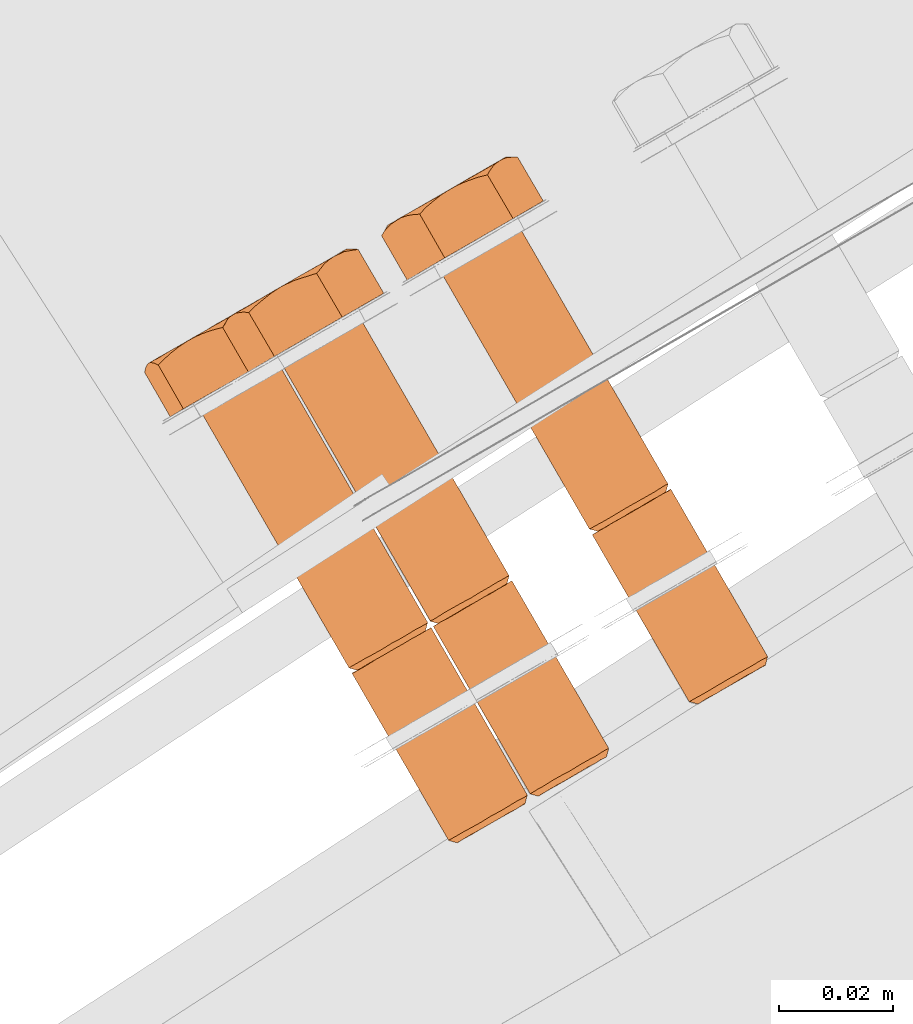
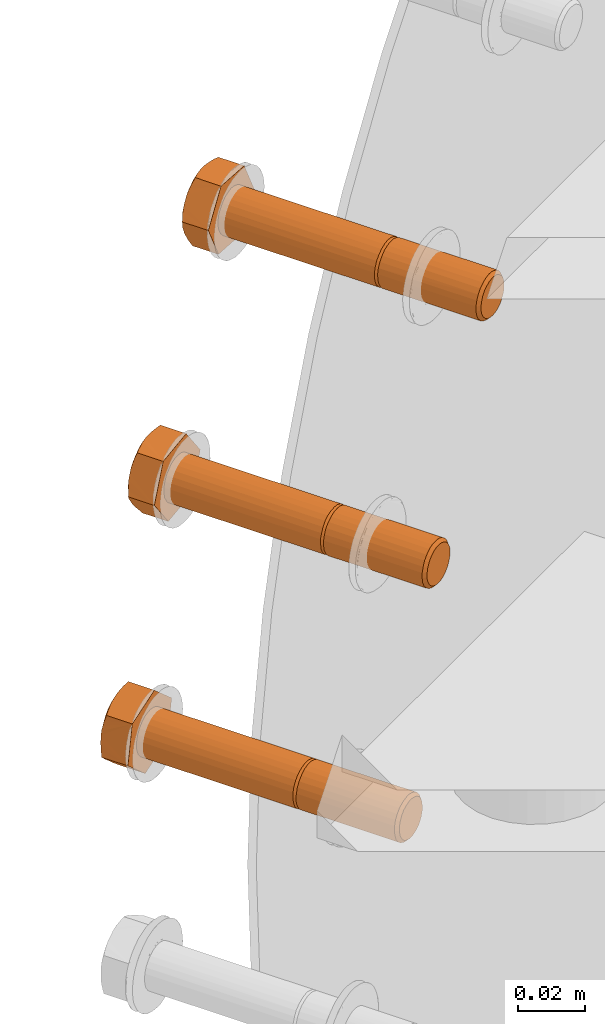
# One storey, part 71 of 126: 3 proxies.
"""IFC2X3 building model written with IfcOpenShell, lengths in millimetres."""

from ifc_helpers import new_model, si_unit, origin, origin_with_axes, place, context, project, spatial, faceted_brep, material, element, save


model = new_model("IFC2X3")

# Units and contexts
context_of_model_1 = context(None, 3, precision=0.1, world=origin())
context_of_model_2 = context(None, 3, precision=0.1, world=origin())
ifc_project = project(units=[si_unit("LENGTHUNIT", "METRE", prefix="MILLI"), si_unit("AREAUNIT", "SQUARE_METRE", prefix="CENTI"), si_unit("VOLUMEUNIT", "CUBIC_METRE", prefix="CENTI"), si_unit("MASSUNIT", "GRAM", prefix="KILO")], contexts=[context_of_model_1, context_of_model_2])

# Site, building, storey
site_placement = place(None, origin_with_axes())
site = spatial("IfcSite", under=ifc_project, at=site_placement, CompositionType="ELEMENT")
building_placement = place(site_placement, origin_with_axes())
building = spatial("IfcBuilding", under=site, at=building_placement, CompositionType="ELEMENT")
storey_placement = place(building_placement, origin_with_axes())
storey = spatial("IfcBuildingStorey", under=building, at=storey_placement, CompositionType="ELEMENT")

# Proxies
ifc_material = material(Name="STAHL")
proxy_1_placement = place(storey_placement, origin_with_axes())
element("IfcBuildingElementProxy", 1, at=proxy_1_placement, inside=storey, material=ifc_material, Name="profile", context=context_of_model_2, shape_type="Brep", body=[
    faceted_brep([(3653.6, 14673.4, 941.1), (3652.2, 14673.9, 941.5), (3651.7, 14673.6, 939.7), (3653.2, 14673.2, 939.5), (3654.4, 14673.9, 942.5), (3653.1, 14674.4, 943.2), (3655.4, 14674.5, 943.7), (3654.3, 14675.1, 944.5), (3656.7, 14675.2, 944.5), (3655.8, 14675.9, 945.5), (3658.1, 14676.0, 945.0), (3657.4, 14676.8, 946.0), (3659.5, 14676.8, 945.0), (3659.0, 14677.8, 946.1), (3660.9, 14677.6, 944.7), (3660.7, 14678.7, 945.7), (3662.2, 14678.4, 944.0), (3662.2, 14679.6, 944.9), (3663.4, 14679.0, 943.0), (3663.5, 14680.4, 943.7), (3664.2, 14679.5, 941.6), (3664.5, 14680.9, 942.2), (3664.8, 14679.9, 940.1), (3665.2, 14681.3, 940.4), (3665.0, 14680.0, 938.5), (3665.4, 14681.5, 938.5), (3664.9, 14679.9, 936.8), (3665.3, 14681.4, 936.6), (3636.1, 14703.7, 941.1), (3634.7, 14704.2, 941.5), (3634.2, 14703.9, 939.7), (3635.7, 14703.5, 939.5), (3636.9, 14704.2, 942.5), (3635.6, 14704.7, 943.2), (3637.9, 14704.8, 943.7), (3636.8, 14705.4, 944.5), (3639.2, 14705.5, 944.5), (3638.3, 14706.2, 945.5), (3640.6, 14706.3, 945.0), (3639.9, 14707.1, 946.0), (3642.0, 14707.1, 945.0), (3641.5, 14708.1, 946.1), (3643.4, 14707.9, 944.7), (3643.2, 14709.0, 945.7), (3644.7, 14708.7, 944.0), (3644.7, 14709.9, 944.9), (3645.9, 14709.3, 943.0), (3646.0, 14710.7, 943.7), (3646.7, 14709.8, 941.6), (3647.0, 14711.2, 942.2), (3647.3, 14710.2, 940.1), (3647.7, 14711.6, 940.4), (3647.5, 14710.3, 938.5), (3647.9, 14711.8, 938.5), (3647.4, 14710.2, 936.8), (3647.8, 14711.7, 936.6), (3664.8, 14681.1, 934.8), (3647.8, 14710.5, 934.8), (3648.3, 14710.8, 936.6), (3663.9, 14680.6, 933.1), (3646.9, 14710.0, 933.1), (3662.7, 14679.9, 931.8), (3645.7, 14709.3, 931.8), (3661.3, 14679.1, 930.8), (3644.3, 14708.4, 930.8), (3659.7, 14678.1, 930.3), (3642.7, 14707.5, 930.3), (3658.0, 14677.2, 930.2), (3641.0, 14706.6, 930.2), (3656.4, 14676.2, 930.5), (3639.4, 14705.6, 930.5), (3654.8, 14675.4, 931.4), (3637.9, 14704.7, 931.4), (3653.5, 14674.6, 932.6), (3636.6, 14704.0, 932.6), (3652.5, 14674.0, 934.1), (3635.6, 14703.4, 934.1), (3651.9, 14673.6, 935.9), (3634.9, 14703.0, 935.9), (3651.6, 14673.5, 937.8), (3634.6, 14702.9, 937.8), (3634.8, 14702.9, 939.7), (3607.8, 14750.9, 941.5), (3607.3, 14750.6, 939.7), (3608.7, 14751.4, 943.2), (3609.9, 14752.1, 944.5), (3611.3, 14752.9, 945.5), (3612.9, 14753.8, 946.0), (3614.6, 14754.8, 946.1), (3616.2, 14755.7, 945.7), (3617.7, 14756.6, 944.9), (3619.0, 14757.4, 943.7), (3620.0, 14757.9, 942.2), (3620.7, 14758.3, 940.4), (3621.0, 14758.5, 938.5), (3620.8, 14758.4, 936.6), (3634.1, 14703.8, 937.8), (3607.1, 14750.5, 937.8), (3607.4, 14750.6, 935.9), (3634.4, 14704.0, 935.9), (3647.3, 14711.4, 934.8), (3620.3, 14758.1, 934.8), (3646.4, 14710.9, 933.1), (3619.4, 14757.6, 933.1), (3645.2, 14710.2, 931.8), (3618.2, 14756.9, 931.8), (3643.8, 14709.4, 930.8), (3616.8, 14756.1, 930.8), (3642.2, 14708.5, 930.3), (3615.2, 14755.1, 930.3), (3640.5, 14707.5, 930.2), (3613.5, 14754.2, 930.2), (3638.9, 14706.5, 930.5), (3611.9, 14753.2, 930.5), (3637.3, 14705.7, 931.4), (3610.4, 14752.4, 931.4), (3636.0, 14704.9, 932.6), (3609.1, 14751.6, 932.6), (3635.0, 14704.3, 934.1), (3608.1, 14751.0, 934.1), (3602.7, 14747.9, 933.7), (3611.7, 14753.1, 924.6), (3623.1, 14759.7, 929.0), (3625.4, 14761.0, 942.6), (3616.4, 14755.8, 951.7), (3605.0, 14749.3, 947.3), (3607.2, 14760.9, 924.6), (3608.6, 14762.2, 925.2), (3610.0, 14763.5, 925.8), (3611.2, 14764.3, 926.3), (3612.4, 14765.1, 926.8), (3614.0, 14765.9, 927.4), (3615.7, 14766.6, 928.0), (3617.1, 14767.0, 928.5), (3618.6, 14767.4, 929.0), (3614.1, 14766.0, 927.6), (3615.6, 14766.9, 928.8), (3616.9, 14767.7, 930.2), (3617.9, 14768.3, 931.9), (3618.7, 14768.7, 933.8), (3618.8, 14768.5, 932.8), (3618.7, 14768.1, 930.9), (3619.0, 14768.8, 934.3), (3619.2, 14769.0, 935.8), (3602.2, 14759.2, 929.1), (3603.7, 14760.0, 927.9), (3605.3, 14761.0, 927.0), (3607.0, 14762.0, 926.4), (3608.8, 14763.0, 926.2), (3610.6, 14764.1, 926.3), (3606.0, 14760.6, 925.6), (3604.8, 14760.3, 926.6), (3603.5, 14759.8, 927.9), (3598.2, 14755.7, 933.7), (3598.3, 14756.2, 935.3), (3598.4, 14756.6, 936.8), (3598.6, 14757.0, 938.6), (3598.9, 14757.3, 940.5), (3598.7, 14757.1, 938.4), (3598.8, 14757.2, 936.3), (3599.2, 14757.5, 934.3), (3599.9, 14757.9, 932.4), (3600.9, 14758.5, 930.6), (3601.2, 14758.6, 930.1), (3600.3, 14757.9, 931.1), (3599.3, 14756.8, 932.4), (3619.6, 14769.1, 937.7), (3620.1, 14769.1, 939.5), (3620.5, 14769.0, 941.0), (3621.0, 14768.8, 942.6), (3619.4, 14768.5, 943.9), (3618.0, 14768.1, 945.2), (3616.9, 14767.6, 946.2), (3615.9, 14767.1, 947.2), (3614.7, 14766.3, 948.4), (3613.6, 14765.4, 949.7), (3612.8, 14764.5, 950.7), (3611.9, 14763.6, 951.7), (3600.6, 14757.0, 947.3), (3601.7, 14758.1, 947.8), (3602.8, 14759.1, 948.3), (3604.2, 14760.2, 948.9), (3605.7, 14761.2, 949.5), (3604.1, 14760.3, 948.7), (3602.5, 14759.4, 947.5), (3601.2, 14758.6, 946.1), (3600.2, 14758.0, 944.4), (3599.4, 14757.6, 942.5), (3599.5, 14757.4, 943.5), (3600.0, 14757.3, 945.3), (3599.1, 14757.4, 942.0), (3607.0, 14761.9, 950.0), (3608.3, 14762.5, 950.5), (3610.0, 14763.1, 951.1), (3614.4, 14766.3, 948.4), (3612.8, 14765.3, 949.3), (3611.1, 14764.3, 949.9), (3609.3, 14763.3, 950.1), (3607.5, 14762.2, 950.0), (3619.4, 14769.1, 937.9), (3619.3, 14769.1, 940.0), (3618.9, 14768.8, 942.0), (3618.2, 14768.4, 943.9), (3617.2, 14767.8, 945.7), (3635.3, 14703.2, 941.5), (3635.6, 14703.4, 937.8), (3635.8, 14703.5, 936.2), (3636.4, 14703.9, 934.7), (3637.3, 14704.4, 933.3), (3638.4, 14705.0, 932.3), (3639.7, 14705.8, 931.6), (3641.1, 14706.6, 931.2), (3642.5, 14707.4, 931.3), (3643.9, 14708.2, 931.8), (3645.2, 14708.9, 932.6), (3646.2, 14709.5, 933.8), (3647.0, 14710.0, 935.2), (3636.2, 14703.7, 943.2), (3637.4, 14704.4, 944.5), (3638.8, 14705.3, 945.5), (3640.4, 14706.2, 946.0), (3642.1, 14707.2, 946.1), (3643.7, 14708.1, 945.7), (3645.2, 14709.0, 944.9), (3646.5, 14709.7, 943.7), (3647.5, 14710.3, 942.2), (3648.2, 14710.7, 940.4), (3648.5, 14710.9, 938.5), (3653.1, 14673.1, 937.8), (3653.3, 14673.2, 936.2), (3653.9, 14673.6, 934.7), (3654.8, 14674.1, 933.3), (3655.9, 14674.7, 932.3), (3657.2, 14675.5, 931.6), (3658.6, 14676.3, 931.2), (3660.0, 14677.1, 931.3), (3661.4, 14677.9, 931.8), (3662.7, 14678.6, 932.6), (3663.7, 14679.2, 933.8), (3664.5, 14679.7, 935.2)], [[[0, 1, 2, 3]], [[4, 5, 1, 0]], [[6, 7, 5, 4]], [[8, 9, 7, 6]], [[10, 11, 9, 8]], [[12, 13, 11, 10]], [[14, 15, 13, 12]], [[16, 17, 15, 14]], [[18, 19, 17, 16]], [[20, 21, 19, 18]], [[22, 23, 21, 20]], [[24, 25, 23, 22]], [[26, 27, 25, 24]], [[28, 29, 30, 31]], [[32, 33, 29, 28]], [[34, 35, 33, 32]], [[36, 37, 35, 34]], [[38, 39, 37, 36]], [[40, 41, 39, 38]], [[42, 43, 41, 40]], [[44, 45, 43, 42]], [[46, 47, 45, 44]], [[48, 49, 47, 46]], [[50, 51, 49, 48]], [[52, 53, 51, 50]], [[54, 55, 53, 52]], [[27, 56, 57, 58]], [[56, 59, 60, 57]], [[59, 61, 62, 60]], [[61, 63, 64, 62]], [[63, 65, 66, 64]], [[65, 67, 68, 66]], [[67, 69, 70, 68]], [[69, 71, 72, 70]], [[71, 73, 74, 72]], [[73, 75, 76, 74]], [[75, 77, 78, 76]], [[77, 79, 80, 78]], [[79, 2, 81, 80]], [[29, 82, 83, 30]], [[29, 33, 84, 82]], [[33, 35, 85, 84]], [[35, 37, 86, 85]], [[37, 39, 87, 86]], [[39, 41, 88, 87]], [[41, 43, 89, 88]], [[43, 45, 90, 89]], [[45, 47, 91, 90]], [[47, 49, 92, 91]], [[49, 51, 93, 92]], [[51, 53, 94, 93]], [[55, 95, 94, 53]], [[96, 97, 98, 99]], [[30, 83, 97, 96]], [[100, 101, 95, 55]], [[102, 103, 101, 100]], [[104, 105, 103, 102]], [[106, 107, 105, 104]], [[108, 109, 107, 106]], [[110, 111, 109, 108]], [[112, 113, 111, 110]], [[114, 115, 113, 112]], [[116, 117, 115, 114]], [[118, 119, 117, 116]], [[99, 98, 119, 118]], [[120, 121, 122, 123, 124, 125, 86, 87, 88, 89, 90, 91, 92, 93, 94, 95, 101, 103, 105, 107, 109, 111, 113, 115, 117, 119, 98, 97, 83, 82, 84, 85, 86, 125]], [[121, 126, 127, 128, 129, 130, 131, 132, 133, 134, 122]], [[130, 135, 136, 137, 138, 139, 140, 141, 134, 133, 132, 131]], [[142, 140, 139]], [[143, 142, 139]], [[144, 145, 146, 147, 148, 149, 129, 128, 127, 126, 150, 151, 152]], [[130, 129, 149]], [[153, 154, 155, 156, 157, 158, 159, 160, 161, 162, 163, 164, 165]], [[144, 163, 162]], [[122, 134, 141, 140, 142, 143, 166, 167, 168, 169, 123]], [[124, 123, 169, 170, 171, 172, 173, 174, 175, 176, 177]], [[178, 179, 180, 181, 182, 183, 184, 185, 186, 187, 188, 189]], [[190, 188, 187]], [[157, 190, 187]], [[191, 192, 193, 177, 176, 175, 174, 173, 194, 195, 196, 197, 198]], [[182, 191, 198]], [[172, 171, 170, 169, 168, 167, 166, 143, 199, 200, 201, 202, 203]], [[173, 172, 203]], [[125, 124, 177, 193, 192, 191, 182, 181, 180, 179, 178]], [[120, 125, 178, 189, 188, 190, 157, 156, 155, 154, 153]], [[120, 153, 165, 164, 163, 144, 152, 151, 150, 126, 121]], [[158, 157, 187, 186, 185, 184, 183, 182, 198, 197, 196, 195, 194, 173, 203, 202, 201, 200, 199, 143, 139, 138, 137, 136, 135, 130, 149, 148, 147, 146, 145, 144, 162, 161, 160, 159]], [[80, 81, 204, 28, 31, 205, 206, 207, 208, 209, 210, 211, 212, 213, 214, 215, 216, 54, 52, 50, 48, 46, 44, 42, 40, 38, 36, 34, 32, 28, 204, 217, 218, 219, 220, 221, 222, 223, 224, 225, 226, 227, 58, 57, 60, 62, 64, 66, 68, 70, 72, 74, 76, 78]], [[100, 55, 54, 216]], [[102, 100, 216, 215]], [[104, 102, 215, 214]], [[106, 104, 214, 213]], [[108, 106, 213, 212]], [[110, 108, 212, 211]], [[112, 110, 211, 210]], [[114, 112, 210, 209]], [[116, 114, 209, 208]], [[118, 116, 208, 207]], [[99, 118, 207, 206]], [[96, 99, 206, 205]], [[31, 30, 96, 205]], [[27, 58, 227, 25]], [[2, 1, 204, 81]], [[5, 217, 204, 1]], [[7, 218, 217, 5]], [[9, 219, 218, 7]], [[11, 220, 219, 9]], [[13, 221, 220, 11]], [[15, 222, 221, 13]], [[17, 223, 222, 15]], [[19, 224, 223, 17]], [[21, 225, 224, 19]], [[23, 226, 225, 21]], [[25, 227, 226, 23]], [[228, 229, 230, 231, 232, 233, 234, 235, 236, 237, 238, 239, 26, 24, 22, 20, 18, 16, 14, 12, 10, 8, 6, 4, 0, 3]], [[239, 56, 27, 26]], [[238, 59, 56, 239]], [[237, 61, 59, 238]], [[236, 63, 61, 237]], [[235, 65, 63, 236]], [[234, 67, 65, 235]], [[233, 69, 67, 234]], [[232, 71, 69, 233]], [[231, 73, 71, 232]], [[230, 75, 73, 231]], [[229, 77, 75, 230]], [[228, 79, 77, 229]], [[3, 2, 79, 228]]]),
])
proxy_2_placement = place(storey_placement, origin_with_axes())
element("IfcBuildingElementProxy", 2, at=proxy_2_placement, inside=storey, material=ifc_material, Name="profile", context=context_of_model_2, shape_type="Brep", body=[
    faceted_brep([(3667.2, 14682.5, 1025.6), (3666.4, 14682.0, 1023.9), (3667.8, 14681.6, 1023.5), (3668.5, 14682.0, 1024.9), (3668.3, 14683.1, 1027.0), (3669.5, 14682.6, 1026.1), (3669.7, 14684.0, 1028.0), (3670.7, 14683.3, 1027.0), (3671.3, 14684.9, 1028.6), (3672.0, 14684.0, 1027.6), (3673.0, 14685.8, 1028.8), (3673.5, 14684.9, 1027.7), (3674.6, 14686.8, 1028.5), (3674.9, 14685.7, 1027.5), (3676.2, 14687.7, 1027.8), (3676.2, 14686.5, 1026.8), (3677.5, 14688.4, 1026.6), (3677.4, 14687.1, 1025.9), (3678.6, 14689.1, 1025.2), (3678.3, 14687.7, 1024.6), (3679.3, 14689.5, 1023.4), (3679.0, 14688.0, 1023.1), (3679.7, 14689.7, 1021.5), (3679.3, 14688.2, 1021.4), (3679.6, 14689.7, 1019.6), (3679.2, 14688.2, 1019.8), (3679.2, 14689.4, 1017.8), (3678.8, 14688.0, 1018.2), (3649.7, 14712.8, 1025.6), (3648.9, 14712.3, 1023.9), (3650.3, 14711.9, 1023.5), (3651.0, 14712.3, 1024.9), (3650.8, 14713.5, 1027.0), (3652.0, 14712.9, 1026.1), (3652.2, 14714.3, 1028.0), (3653.2, 14713.6, 1027.0), (3653.8, 14715.2, 1028.6), (3654.5, 14714.4, 1027.6), (3655.5, 14716.1, 1028.8), (3656.0, 14715.2, 1027.7), (3657.1, 14717.1, 1028.5), (3657.4, 14716.0, 1027.5), (3658.7, 14718.0, 1027.8), (3658.7, 14716.8, 1026.8), (3660.0, 14718.8, 1026.6), (3659.9, 14717.4, 1025.9), (3661.1, 14719.4, 1025.2), (3660.8, 14718.0, 1024.6), (3661.8, 14719.8, 1023.4), (3661.5, 14718.3, 1023.1), (3662.2, 14720.0, 1021.5), (3661.8, 14718.5, 1021.4), (3662.1, 14720.0, 1019.6), (3661.7, 14718.5, 1019.8), (3661.7, 14719.7, 1017.8), (3661.3, 14718.3, 1018.2), (3649.4, 14711.4, 1023.9), (3648.9, 14711.1, 1022.0), (3665.9, 14681.7, 1022.0), (3678.3, 14688.9, 1016.1), (3661.4, 14718.3, 1016.1), (3662.2, 14718.8, 1017.8), (3677.2, 14688.3, 1014.7), (3660.2, 14717.6, 1014.7), (3675.8, 14687.5, 1013.6), (3658.8, 14716.8, 1013.6), (3674.2, 14686.5, 1013.0), (3657.2, 14715.9, 1013.0), (3672.5, 14685.6, 1012.8), (3655.6, 14715.0, 1012.8), (3670.9, 14684.6, 1013.1), (3653.9, 14714.0, 1013.1), (3669.4, 14683.7, 1013.9), (3652.4, 14713.1, 1013.9), (3668.0, 14683.0, 1015.0), (3651.0, 14712.3, 1015.0), (3666.9, 14682.3, 1016.5), (3650.0, 14711.7, 1016.5), (3666.2, 14681.9, 1018.2), (3649.2, 14711.3, 1018.2), (3665.9, 14681.7, 1020.1), (3648.9, 14711.1, 1020.1), (3635.1, 14766.7, 1019.6), (3635.2, 14766.7, 1021.5), (3634.7, 14766.4, 1017.8), (3622.7, 14759.5, 1025.6), (3621.9, 14759.0, 1023.9), (3623.9, 14760.1, 1027.0), (3625.3, 14761.0, 1028.0), (3626.8, 14761.9, 1028.6), (3628.5, 14762.8, 1028.8), (3630.2, 14763.8, 1028.5), (3631.7, 14764.7, 1027.8), (3633.0, 14765.5, 1026.6), (3634.1, 14766.1, 1025.2), (3634.8, 14766.5, 1023.4), (3660.8, 14719.2, 1016.1), (3633.9, 14765.9, 1016.1), (3659.7, 14718.6, 1014.7), (3632.7, 14765.3, 1014.7), (3658.3, 14717.8, 1013.6), (3631.3, 14764.5, 1013.6), (3656.7, 14716.9, 1013.0), (3629.7, 14763.5, 1013.0), (3655.0, 14715.9, 1012.8), (3628.1, 14762.6, 1012.8), (3653.4, 14714.9, 1013.1), (3626.4, 14761.6, 1013.1), (3651.9, 14714.0, 1013.9), (3624.9, 14760.7, 1013.9), (3650.5, 14713.3, 1015.0), (3623.5, 14760.0, 1015.0), (3649.4, 14712.7, 1016.5), (3622.5, 14759.3, 1016.5), (3648.7, 14712.2, 1018.2), (3621.7, 14758.9, 1018.2), (3648.4, 14712.0, 1020.1), (3621.4, 14758.7, 1020.1), (3648.4, 14712.1, 1022.0), (3621.4, 14758.8, 1022.0), (3616.4, 14755.8, 1019.0), (3623.7, 14760.1, 1008.0), (3635.6, 14766.9, 1009.8), (3640.2, 14769.6, 1022.6), (3632.9, 14765.4, 1033.6), (3621.0, 14758.5, 1031.8), (3619.2, 14767.8, 1008.0), (3620.7, 14769.2, 1008.3), (3622.2, 14770.5, 1008.5), (3623.4, 14771.4, 1008.7), (3624.7, 14772.2, 1008.9), (3626.3, 14773.0, 1009.2), (3628.1, 14773.7, 1009.4), (3629.5, 14774.2, 1009.6), (3631.1, 14774.7, 1009.8), (3626.4, 14773.2, 1009.4), (3628.1, 14774.1, 1010.2), (3629.6, 14775.0, 1011.3), (3631.0, 14775.8, 1012.7), (3632.1, 14776.4, 1014.4), (3632.0, 14776.1, 1013.4), (3631.5, 14775.5, 1011.7), (3632.4, 14776.6, 1014.8), (3632.9, 14776.9, 1016.2), (3615.0, 14766.6, 1013.5), (3616.3, 14767.3, 1012.0), (3617.7, 14768.1, 1010.7), (3619.3, 14769.1, 1009.7), (3621.0, 14770.1, 1009.1), (3622.8, 14771.1, 1008.8), (3618.2, 14767.7, 1009.3), (3617.2, 14767.5, 1010.5), (3616.1, 14767.1, 1012.0), (3611.9, 14763.6, 1019.0), (3612.3, 14764.2, 1020.5), (3612.6, 14764.8, 1021.9), (3613.1, 14765.4, 1023.7), (3613.7, 14765.8, 1025.4), (3613.1, 14765.5, 1023.4), (3612.9, 14765.4, 1021.3), (3613.0, 14765.4, 1019.3), (3613.4, 14765.6, 1017.2), (3614.1, 14766.0, 1015.3), (3614.3, 14766.1, 1014.7), (3613.6, 14765.5, 1015.9), (3612.7, 14764.6, 1017.4), (3633.6, 14777.2, 1018.0), (3634.3, 14777.3, 1019.7), (3635.0, 14777.4, 1021.2), (3635.7, 14777.3, 1022.6), (3634.4, 14777.1, 1024.2), (3633.2, 14776.9, 1025.7), (3632.4, 14776.5, 1026.9), (3631.5, 14776.1, 1028.1), (3630.6, 14775.5, 1029.6), (3629.7, 14774.7, 1031.1), (3629.1, 14773.9, 1032.4), (3628.4, 14773.1, 1033.6), (3614.8, 14766.2, 1028.2), (3615.6, 14766.3, 1030.0), (3616.5, 14766.2, 1031.8), (3617.7, 14767.4, 1032.0), (3618.9, 14768.4, 1032.2), (3620.4, 14769.6, 1032.5), (3621.9, 14770.6, 1032.7), (3620.2, 14769.6, 1032.3), (3618.5, 14768.6, 1031.5), (3617.0, 14767.7, 1030.3), (3615.6, 14766.9, 1028.9), (3614.5, 14766.3, 1027.3), (3614.2, 14766.1, 1026.8), (3623.3, 14771.3, 1032.9), (3624.6, 14771.9, 1033.1), (3626.5, 14772.5, 1033.4), (3630.3, 14775.4, 1029.7), (3628.9, 14774.6, 1030.9), (3627.3, 14773.7, 1031.9), (3625.5, 14772.7, 1032.5), (3623.7, 14771.6, 1032.8), (3633.4, 14777.2, 1018.2), (3633.7, 14777.4, 1020.3), (3633.6, 14777.3, 1022.4), (3633.2, 14777.1, 1024.4), (3632.5, 14776.7, 1026.4), (3650.2, 14711.9, 1025.6), (3649.9, 14711.7, 1021.9), (3649.8, 14711.6, 1020.2), (3650.1, 14711.8, 1018.6), (3650.8, 14712.2, 1017.1), (3651.7, 14712.7, 1015.8), (3652.9, 14713.4, 1014.8), (3654.2, 14714.1, 1014.2), (3655.6, 14715.0, 1013.9), (3657.1, 14715.8, 1014.1), (3658.4, 14716.6, 1014.6), (3659.6, 14717.3, 1015.5), (3660.6, 14717.9, 1016.7), (3651.4, 14712.5, 1027.0), (3652.8, 14713.3, 1028.0), (3654.3, 14714.2, 1028.6), (3656.0, 14715.2, 1028.8), (3657.7, 14716.2, 1028.5), (3659.2, 14717.0, 1027.8), (3660.5, 14717.8, 1026.6), (3661.6, 14718.4, 1025.2), (3662.3, 14718.9, 1023.4), (3662.7, 14719.1, 1021.5), (3662.6, 14719.0, 1019.6), (3667.3, 14681.3, 1020.2), (3667.6, 14681.5, 1018.6), (3668.3, 14681.9, 1017.1), (3669.2, 14682.4, 1015.8), (3670.4, 14683.1, 1014.8), (3671.7, 14683.8, 1014.2), (3673.1, 14684.7, 1013.9), (3674.6, 14685.5, 1014.1), (3675.9, 14686.3, 1014.6), (3677.1, 14687.0, 1015.5), (3678.1, 14687.6, 1016.7), (3667.4, 14681.3, 1021.9)], [[[0, 1, 2, 3]], [[4, 0, 3, 5]], [[6, 4, 5, 7]], [[8, 6, 7, 9]], [[10, 8, 9, 11]], [[12, 10, 11, 13]], [[14, 12, 13, 15]], [[16, 14, 15, 17]], [[18, 16, 17, 19]], [[20, 18, 19, 21]], [[22, 20, 21, 23]], [[24, 22, 23, 25]], [[26, 24, 25, 27]], [[28, 29, 30, 31]], [[32, 28, 31, 33]], [[34, 32, 33, 35]], [[36, 34, 35, 37]], [[38, 36, 37, 39]], [[40, 38, 39, 41]], [[42, 40, 41, 43]], [[44, 42, 43, 45]], [[46, 44, 45, 47]], [[48, 46, 47, 49]], [[50, 48, 49, 51]], [[52, 50, 51, 53]], [[54, 52, 53, 55]], [[1, 56, 57, 58]], [[59, 60, 61, 26]], [[62, 63, 60, 59]], [[64, 65, 63, 62]], [[66, 67, 65, 64]], [[68, 69, 67, 66]], [[70, 71, 69, 68]], [[72, 73, 71, 70]], [[74, 75, 73, 72]], [[76, 77, 75, 74]], [[78, 79, 77, 76]], [[80, 81, 79, 78]], [[58, 57, 81, 80]], [[52, 82, 83, 50]], [[54, 84, 82, 52]], [[29, 28, 85, 86]], [[32, 87, 85, 28]], [[34, 88, 87, 32]], [[36, 89, 88, 34]], [[38, 90, 89, 36]], [[40, 91, 90, 38]], [[42, 92, 91, 40]], [[44, 93, 92, 42]], [[46, 94, 93, 44]], [[48, 95, 94, 46]], [[50, 83, 95, 48]], [[54, 96, 97, 84]], [[96, 98, 99, 97]], [[98, 100, 101, 99]], [[100, 102, 103, 101]], [[102, 104, 105, 103]], [[104, 106, 107, 105]], [[106, 108, 109, 107]], [[108, 110, 111, 109]], [[110, 112, 113, 111]], [[112, 114, 115, 113]], [[114, 116, 117, 115]], [[116, 118, 119, 117]], [[29, 86, 119, 118]], [[120, 121, 122, 123, 124, 125, 89, 90, 91, 92, 93, 94, 95, 83, 82, 84, 97, 99, 101, 103, 105, 107, 109, 111, 113, 115, 117, 119, 86, 85, 87, 88, 89, 125]], [[121, 126, 127, 128, 129, 130, 131, 132, 133, 134, 122]], [[130, 135, 136, 137, 138, 139, 140, 141, 134, 133, 132, 131]], [[142, 140, 139]], [[143, 142, 139]], [[144, 145, 146, 147, 148, 149, 129, 128, 127, 126, 150, 151, 152]], [[130, 129, 149]], [[153, 154, 155, 156, 157, 158, 159, 160, 161, 162, 163, 164, 165]], [[144, 163, 162]], [[122, 134, 141, 140, 142, 143, 166, 167, 168, 169, 123]], [[124, 123, 169, 170, 171, 172, 173, 174, 175, 176, 177]], [[178, 179, 180, 181, 182, 183, 184, 185, 186, 187, 188, 189]], [[190, 178, 189]], [[157, 190, 189]], [[191, 192, 193, 177, 176, 175, 174, 173, 194, 195, 196, 197, 198]], [[184, 191, 198]], [[172, 171, 170, 169, 168, 167, 166, 143, 199, 200, 201, 202, 203]], [[173, 172, 203]], [[125, 124, 177, 193, 192, 191, 184, 183, 182, 181, 180]], [[120, 125, 180, 179, 178, 190, 157, 156, 155, 154, 153]], [[120, 153, 165, 164, 163, 144, 152, 151, 150, 126, 121]], [[159, 158, 157, 189, 188, 187, 186, 185, 184, 198, 197, 196, 195, 194, 173, 203, 202, 201, 200, 199, 143, 139, 138, 137, 136, 135, 130, 149, 148, 147, 146, 145, 144, 162, 161, 160]], [[81, 57, 56, 204, 31, 30, 205, 206, 207, 208, 209, 210, 211, 212, 213, 214, 215, 216, 55, 53, 51, 49, 47, 45, 43, 41, 39, 37, 35, 33, 31, 204, 217, 218, 219, 220, 221, 222, 223, 224, 225, 226, 227, 61, 60, 63, 65, 67, 69, 71, 73, 75, 77, 79]], [[96, 54, 55, 216]], [[98, 96, 216, 215]], [[100, 98, 215, 214]], [[102, 100, 214, 213]], [[104, 102, 213, 212]], [[106, 104, 212, 211]], [[108, 106, 211, 210]], [[110, 108, 210, 209]], [[112, 110, 209, 208]], [[114, 112, 208, 207]], [[116, 114, 207, 206]], [[118, 116, 206, 205]], [[30, 29, 118, 205]], [[1, 0, 204, 56]], [[0, 4, 217, 204]], [[4, 6, 218, 217]], [[6, 8, 219, 218]], [[8, 10, 220, 219]], [[10, 12, 221, 220]], [[12, 14, 222, 221]], [[14, 16, 223, 222]], [[16, 18, 224, 223]], [[18, 20, 225, 224]], [[20, 22, 226, 225]], [[22, 24, 227, 226]], [[24, 26, 61, 227]], [[228, 229, 230, 231, 232, 233, 234, 235, 236, 237, 238, 27, 25, 23, 21, 19, 17, 15, 13, 11, 9, 7, 5, 3, 2, 239]], [[59, 26, 27, 238]], [[62, 59, 238, 237]], [[64, 62, 237, 236]], [[66, 64, 236, 235]], [[68, 66, 235, 234]], [[70, 68, 234, 233]], [[72, 70, 233, 232]], [[74, 72, 232, 231]], [[76, 74, 231, 230]], [[78, 76, 230, 229]], [[80, 78, 229, 228]], [[58, 80, 228, 239]], [[2, 1, 58, 239]]]),
])
proxy_3_placement = place(storey_placement, origin_with_axes())
element("IfcBuildingElementProxy", 3, at=proxy_3_placement, inside=storey, material=ifc_material, Name="profile", context=context_of_model_2, shape_type="Brep", body=[
    faceted_brep([(3696.0, 14699.1, 1104.6), (3694.9, 14698.5, 1103.1), (3696.2, 14698.0, 1102.5), (3697.2, 14698.6, 1103.8), (3697.4, 14699.9, 1105.7), (3698.4, 14699.2, 1104.8), (3698.9, 14700.8, 1106.4), (3699.7, 14700.0, 1105.4), (3700.6, 14701.8, 1106.7), (3701.1, 14700.8, 1105.6), (3702.2, 14702.7, 1106.5), (3702.6, 14701.7, 1105.4), (3703.8, 14703.6, 1105.8), (3703.9, 14702.5, 1104.9), (3705.2, 14704.4, 1104.8), (3705.1, 14703.1, 1103.9), (3706.3, 14705.1, 1103.3), (3706.1, 14703.7, 1102.7), (3707.1, 14705.5, 1101.7), (3706.8, 14704.1, 1101.3), (3707.6, 14705.8, 1099.8), (3707.2, 14704.3, 1099.6), (3707.6, 14705.8, 1097.9), (3707.2, 14704.3, 1098.0), (3707.2, 14705.6, 1096.0), (3706.9, 14704.1, 1096.3), (3706.5, 14705.2, 1094.3), (3706.2, 14703.8, 1094.9), (3678.5, 14729.4, 1104.6), (3677.4, 14728.8, 1103.1), (3678.7, 14728.3, 1102.5), (3679.7, 14728.9, 1103.8), (3679.9, 14730.2, 1105.7), (3680.9, 14729.6, 1104.8), (3681.4, 14731.1, 1106.4), (3682.2, 14730.3, 1105.4), (3683.1, 14732.1, 1106.7), (3683.6, 14731.2, 1105.6), (3684.7, 14733.0, 1106.5), (3685.1, 14732.0, 1105.4), (3686.3, 14733.9, 1105.8), (3686.4, 14732.8, 1104.9), (3687.7, 14734.7, 1104.8), (3687.6, 14733.5, 1103.9), (3688.8, 14735.4, 1103.3), (3688.6, 14734.0, 1102.7), (3689.6, 14735.9, 1101.7), (3689.3, 14734.4, 1101.3), (3690.1, 14736.1, 1099.8), (3689.7, 14734.6, 1099.6), (3690.1, 14736.1, 1097.9), (3689.7, 14734.6, 1098.0), (3689.7, 14735.9, 1096.0), (3689.4, 14734.5, 1096.3), (3689.0, 14735.5, 1094.3), (3688.7, 14734.1, 1094.9), (3678.0, 14727.9, 1103.1), (3677.2, 14727.4, 1101.4), (3694.2, 14698.1, 1101.4), (3705.4, 14704.5, 1092.8), (3688.4, 14733.9, 1092.8), (3689.5, 14734.5, 1094.3), (3704.0, 14703.7, 1091.7), (3687.0, 14733.1, 1091.7), (3702.4, 14702.8, 1091.0), (3685.5, 14732.2, 1091.0), (3700.8, 14701.9, 1090.7), (3683.8, 14731.3, 1090.7), (3699.1, 14700.9, 1090.9), (3682.2, 14730.3, 1090.9), (3697.6, 14700.0, 1091.6), (3680.6, 14729.4, 1091.6), (3696.2, 14699.2, 1092.6), (3679.2, 14728.6, 1092.6), (3695.0, 14698.6, 1094.1), (3678.1, 14727.9, 1094.1), (3694.2, 14698.1, 1095.8), (3677.3, 14727.5, 1095.8), (3693.8, 14697.9, 1097.6), (3676.9, 14727.2, 1097.6), (3693.8, 14697.9, 1099.5), (3676.8, 14727.2, 1099.5), (3662.0, 14782.2, 1094.3), (3662.7, 14782.6, 1096.0), (3663.1, 14782.8, 1097.9), (3651.6, 14776.1, 1104.6), (3650.5, 14775.5, 1103.1), (3652.9, 14776.9, 1105.7), (3654.5, 14777.8, 1106.4), (3656.1, 14778.8, 1106.7), (3657.8, 14779.7, 1106.5), (3659.4, 14780.6, 1105.8), (3660.7, 14781.4, 1104.8), (3661.9, 14782.1, 1103.3), (3662.7, 14782.6, 1101.7), (3663.1, 14782.8, 1099.8), (3687.9, 14734.8, 1092.8), (3660.9, 14781.5, 1092.8), (3686.5, 14734.1, 1091.7), (3659.5, 14780.7, 1091.7), (3684.9, 14733.2, 1091.0), (3658.0, 14779.9, 1091.0), (3683.3, 14732.2, 1090.7), (3656.3, 14778.9, 1090.7), (3681.6, 14731.2, 1090.9), (3654.7, 14777.9, 1090.9), (3680.1, 14730.3, 1091.6), (3653.1, 14777.0, 1091.6), (3678.7, 14729.5, 1092.6), (3651.7, 14776.2, 1092.6), (3677.5, 14728.9, 1094.1), (3650.6, 14775.6, 1094.1), (3676.7, 14728.4, 1095.8), (3649.8, 14775.1, 1095.8), (3676.3, 14728.2, 1097.6), (3649.4, 14774.9, 1097.6), (3676.3, 14728.2, 1099.5), (3649.3, 14774.9, 1099.5), (3676.7, 14728.4, 1101.4), (3649.7, 14775.1, 1101.4), (3644.3, 14771.9, 1099.6), (3649.6, 14775.0, 1087.2), (3661.5, 14781.9, 1086.3), (3668.2, 14785.8, 1097.8), (3662.9, 14782.7, 1110.2), (3650.9, 14775.8, 1111.1), (3645.1, 14782.7, 1087.2), (3646.6, 14784.2, 1087.0), (3648.0, 14785.4, 1086.9), (3649.3, 14786.3, 1086.8), (3650.6, 14787.1, 1086.7), (3652.2, 14788.0, 1086.6), (3654.0, 14788.7, 1086.5), (3655.5, 14789.2, 1086.4), (3657.1, 14789.6, 1086.3), (3652.4, 14788.2, 1086.8), (3654.1, 14789.2, 1087.2), (3655.8, 14790.2, 1087.9), (3657.4, 14791.0, 1089.0), (3658.7, 14791.8, 1090.4), (3659.2, 14792.0, 1090.8), (3658.5, 14791.5, 1089.5), (3657.8, 14790.6, 1087.9), (3659.9, 14792.5, 1092.0), (3641.9, 14782.1, 1093.4), (3642.8, 14782.7, 1091.6), (3644.0, 14783.3, 1090.0), (3645.5, 14784.2, 1088.7), (3647.0, 14785.1, 1087.7), (3648.8, 14786.1, 1087.0), (3644.3, 14782.7, 1088.6), (3643.5, 14782.7, 1090.0), (3642.7, 14782.5, 1091.7), (3639.8, 14779.7, 1099.6), (3640.3, 14780.5, 1100.9), (3640.9, 14781.2, 1102.2), (3641.7, 14781.9, 1103.8), (3642.6, 14782.5, 1105.4), (3641.7, 14782.0, 1103.5), (3641.1, 14781.7, 1101.6), (3640.9, 14781.5, 1099.5), (3640.9, 14781.5, 1097.4), (3641.3, 14781.7, 1095.3), (3641.4, 14781.7, 1094.7), (3640.9, 14781.3, 1096.1), (3640.3, 14780.5, 1097.8), (3660.8, 14792.9, 1093.6), (3661.9, 14793.2, 1095.2), (3662.8, 14793.4, 1096.5), (3663.7, 14793.5, 1097.8), (3662.7, 14793.5, 1099.6), (3661.8, 14793.4, 1101.3), (3661.2, 14793.2, 1102.7), (3660.6, 14792.9, 1104.0), (3659.9, 14792.4, 1105.7), (3659.3, 14791.8, 1107.4), (3658.8, 14791.1, 1108.8), (3658.4, 14790.4, 1110.2), (3643.3, 14782.9, 1106.6), (3644.2, 14783.2, 1107.9), (3645.3, 14783.4, 1109.5), (3646.5, 14783.5, 1111.1), (3647.6, 14784.7, 1111.0), (3648.8, 14785.7, 1110.9), (3650.3, 14786.9, 1110.8), (3651.9, 14787.9, 1110.7), (3650.1, 14786.8, 1110.6), (3648.3, 14785.8, 1110.2), (3646.6, 14784.8, 1109.5), (3645.1, 14783.9, 1108.4), (3643.7, 14783.2, 1107.0), (3653.7, 14788.9, 1110.4), (3654.6, 14789.2, 1110.5), (3656.5, 14789.9, 1110.4), (3659.6, 14792.3, 1105.8), (3658.4, 14791.6, 1107.4), (3657.0, 14790.8, 1108.7), (3655.4, 14789.9, 1109.7), (3653.2, 14788.6, 1110.6), (3660.7, 14793.0, 1093.9), (3661.3, 14793.3, 1095.8), (3661.6, 14793.5, 1097.9), (3661.6, 14793.5, 1100.0), (3661.2, 14793.3, 1102.1), (3679.1, 14728.5, 1104.6), (3680.4, 14729.3, 1105.7), (3682.0, 14730.2, 1106.4), (3683.6, 14731.1, 1106.7), (3685.3, 14732.1, 1106.5), (3686.9, 14733.0, 1105.8), (3688.2, 14733.8, 1104.8), (3689.4, 14734.5, 1103.3), (3690.2, 14734.9, 1101.7), (3690.6, 14735.2, 1099.8), (3690.6, 14735.2, 1097.9), (3690.2, 14735.0, 1096.0), (3681.0, 14729.6, 1092.5), (3682.4, 14730.4, 1092.0), (3683.8, 14731.3, 1091.8), (3685.3, 14732.1, 1092.0), (3686.6, 14732.9, 1092.6), (3687.8, 14733.5, 1093.6), (3678.1, 14728.0, 1101.1), (3677.8, 14727.8, 1099.4), (3677.8, 14727.8, 1097.8), (3678.2, 14728.0, 1096.1), (3678.9, 14728.4, 1094.7), (3679.8, 14729.0, 1093.5), (3695.3, 14697.5, 1099.4), (3695.3, 14697.5, 1097.8), (3695.7, 14697.7, 1096.1), (3696.4, 14698.1, 1094.7), (3697.3, 14698.6, 1093.5), (3698.5, 14699.3, 1092.5), (3699.9, 14700.1, 1092.0), (3701.3, 14700.9, 1091.8), (3702.8, 14701.8, 1092.0), (3704.1, 14702.5, 1092.6), (3705.3, 14703.2, 1093.6), (3695.6, 14697.6, 1101.1)], [[[0, 1, 2, 3]], [[4, 0, 3, 5]], [[6, 4, 5, 7]], [[8, 6, 7, 9]], [[10, 8, 9, 11]], [[12, 10, 11, 13]], [[14, 12, 13, 15]], [[16, 14, 15, 17]], [[18, 16, 17, 19]], [[20, 18, 19, 21]], [[22, 20, 21, 23]], [[24, 22, 23, 25]], [[26, 24, 25, 27]], [[28, 29, 30, 31]], [[32, 28, 31, 33]], [[34, 32, 33, 35]], [[36, 34, 35, 37]], [[38, 36, 37, 39]], [[40, 38, 39, 41]], [[42, 40, 41, 43]], [[44, 42, 43, 45]], [[46, 44, 45, 47]], [[48, 46, 47, 49]], [[50, 48, 49, 51]], [[52, 50, 51, 53]], [[54, 52, 53, 55]], [[1, 56, 57, 58]], [[59, 60, 61, 26]], [[62, 63, 60, 59]], [[64, 65, 63, 62]], [[66, 67, 65, 64]], [[68, 69, 67, 66]], [[70, 71, 69, 68]], [[72, 73, 71, 70]], [[74, 75, 73, 72]], [[76, 77, 75, 74]], [[78, 79, 77, 76]], [[80, 81, 79, 78]], [[58, 57, 81, 80]], [[52, 54, 82, 83]], [[52, 83, 84, 50]], [[28, 85, 86, 29]], [[32, 87, 85, 28]], [[34, 88, 87, 32]], [[36, 89, 88, 34]], [[38, 90, 89, 36]], [[40, 91, 90, 38]], [[42, 92, 91, 40]], [[44, 93, 92, 42]], [[46, 94, 93, 44]], [[48, 95, 94, 46]], [[50, 84, 95, 48]], [[96, 97, 82, 54]], [[96, 98, 99, 97]], [[98, 100, 101, 99]], [[100, 102, 103, 101]], [[102, 104, 105, 103]], [[104, 106, 107, 105]], [[106, 108, 109, 107]], [[108, 110, 111, 109]], [[110, 112, 113, 111]], [[112, 114, 115, 113]], [[114, 116, 117, 115]], [[116, 118, 119, 117]], [[118, 29, 86, 119]], [[120, 121, 122, 123, 124, 125, 89, 90, 91, 92, 93, 94, 95, 84, 83, 82, 97, 99, 101, 103, 105, 107, 109, 111, 113, 115, 117, 119, 86, 85, 87, 88, 89, 125]], [[121, 126, 127, 128, 129, 130, 131, 132, 133, 134, 122]], [[130, 135, 136, 137, 138, 139, 140, 141, 142, 134, 133, 132, 131]], [[143, 140, 139]], [[144, 145, 146, 147, 148, 149, 129, 128, 127, 126, 150, 151, 152]], [[130, 129, 149]], [[153, 154, 155, 156, 157, 158, 159, 160, 161, 162, 163, 164, 165]], [[144, 163, 162]], [[122, 134, 142, 141, 140, 143, 166, 167, 168, 169, 123]], [[124, 123, 169, 170, 171, 172, 173, 174, 175, 176, 177]], [[178, 179, 180, 181, 182, 183, 184, 185, 186, 187, 188, 189, 190]], [[157, 178, 190]], [[191, 192, 193, 177, 176, 175, 174, 173, 194, 195, 196, 197]], [[198, 192, 191]], [[185, 198, 191]], [[143, 199, 200, 201, 202, 203, 172, 171, 170, 169, 168, 167, 166]], [[173, 172, 203]], [[125, 124, 177, 193, 192, 198, 185, 184, 183, 182, 181]], [[120, 125, 181, 180, 179, 178, 157, 156, 155, 154, 153]], [[120, 153, 165, 164, 163, 144, 152, 151, 150, 126, 121]], [[160, 159, 158, 157, 190, 189, 188, 187, 186, 185, 191, 197, 196, 195, 194, 173, 203, 202, 201, 200, 199, 143, 139, 138, 137, 136, 135, 130, 149, 148, 147, 146, 145, 144, 162, 161]], [[81, 57, 56, 204, 205, 206, 207, 208, 209, 210, 211, 212, 213, 214, 215, 61, 60, 63, 65, 67, 69, 216, 217, 218, 219, 220, 221, 55, 53, 51, 49, 47, 45, 43, 41, 39, 37, 35, 33, 31, 30, 222, 223, 224, 225, 226, 227, 216, 69, 71, 73, 75, 77, 79]], [[221, 96, 54, 55]], [[220, 98, 96, 221]], [[219, 100, 98, 220]], [[218, 102, 100, 219]], [[217, 104, 102, 218]], [[216, 106, 104, 217]], [[227, 108, 106, 216]], [[226, 110, 108, 227]], [[225, 112, 110, 226]], [[224, 114, 112, 225]], [[223, 116, 114, 224]], [[222, 118, 116, 223]], [[29, 118, 222, 30]], [[0, 204, 56, 1]], [[0, 4, 205, 204]], [[4, 6, 206, 205]], [[6, 8, 207, 206]], [[8, 10, 208, 207]], [[10, 12, 209, 208]], [[12, 14, 210, 209]], [[14, 16, 211, 210]], [[16, 18, 212, 211]], [[18, 20, 213, 212]], [[20, 22, 214, 213]], [[22, 24, 215, 214]], [[24, 26, 61, 215]], [[228, 229, 230, 231, 232, 233, 234, 235, 236, 237, 238, 27, 25, 23, 21, 19, 17, 15, 13, 11, 9, 7, 5, 3, 2, 239]], [[59, 26, 27, 238]], [[62, 59, 238, 237]], [[64, 62, 237, 236]], [[66, 64, 236, 235]], [[68, 66, 235, 234]], [[70, 68, 234, 233]], [[72, 70, 233, 232]], [[74, 72, 232, 231]], [[76, 74, 231, 230]], [[78, 76, 230, 229]], [[80, 78, 229, 228]], [[58, 80, 228, 239]], [[1, 58, 239, 2]]]),
])

save(model, "model.ifc")
